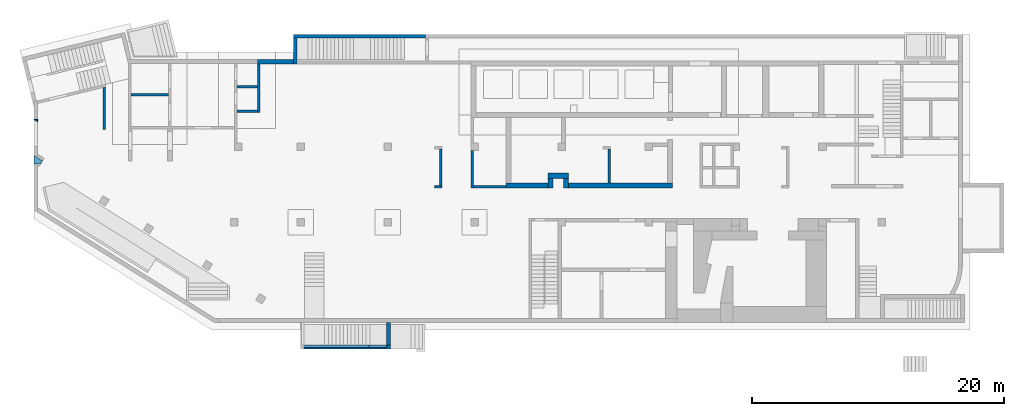
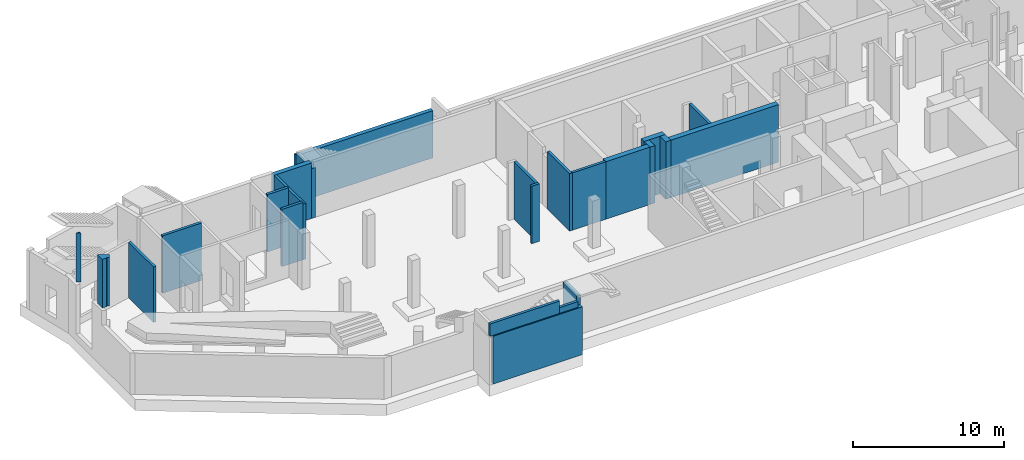
# One storey, part 2 of 9: 24 walls.
"""IFC4 building model written with IfcOpenShell, lengths in millimetres."""

from ifc_helpers import new_model, entity, si_unit, converted_unit, derived_unit, direction, frame, origin, place, context, subcontext, project, spatial, indexed_curve, outline, extrude, material, type_object, element, save


model = new_model("IFC4")

# Units and contexts
model_context = context("Model", 3, precision=0.01, world=origin(), true_north=direction((6.12303176911189e-17, 1.0)))
plan_context = context("Plan", 3, precision=0.01, world=origin(), true_north=direction((6.12303176911189e-17, 1.0)))
body_context = subcontext(model_context, "Body", "Model", "MODEL_VIEW")
ifc_project = project(units=[si_unit("LENGTHUNIT", "METRE", prefix="MILLI"), si_unit("AREAUNIT", "SQUARE_METRE"), si_unit("VOLUMEUNIT", "CUBIC_METRE"), converted_unit("PLANEANGLEUNIT", "DEGREE", entity("IfcRatioMeasure", 0.0174532925199433), si_unit("PLANEANGLEUNIT", "RADIAN"), dimensions=[0, 0, 0, 0, 0, 0, 0]), si_unit("MASSUNIT", "GRAM", prefix="KILO"), derived_unit("MASSDENSITYUNIT", [(si_unit("MASSUNIT", "GRAM", prefix="KILO"), 1), (si_unit("LENGTHUNIT", "METRE"), -3)]), derived_unit("MOMENTOFINERTIAUNIT", [(si_unit("LENGTHUNIT", "METRE"), 4)]), si_unit("TIMEUNIT", "SECOND"), si_unit("FREQUENCYUNIT", "HERTZ"), si_unit("THERMODYNAMICTEMPERATUREUNIT", "DEGREE_CELSIUS"), derived_unit("THERMALTRANSMITTANCEUNIT", [(si_unit("MASSUNIT", "GRAM", prefix="KILO"), 1), (si_unit("THERMODYNAMICTEMPERATUREUNIT", "KELVIN"), -1), (si_unit("TIMEUNIT", "SECOND"), -3)]), derived_unit("VOLUMETRICFLOWRATEUNIT", [(si_unit("LENGTHUNIT", "METRE"), 3), (si_unit("TIMEUNIT", "SECOND"), -1)]), derived_unit("MASSFLOWRATEUNIT", [(si_unit("MASSUNIT", "GRAM", prefix="KILO"), 1), (si_unit("TIMEUNIT", "SECOND"), -1)]), derived_unit("ROTATIONALFREQUENCYUNIT", [(si_unit("TIMEUNIT", "SECOND"), -1)]), si_unit("ELECTRICCURRENTUNIT", "AMPERE"), si_unit("ELECTRICVOLTAGEUNIT", "VOLT"), si_unit("POWERUNIT", "WATT"), si_unit("FORCEUNIT", "NEWTON", prefix="KILO"), si_unit("ILLUMINANCEUNIT", "LUX"), si_unit("LUMINOUSFLUXUNIT", "LUMEN"), si_unit("LUMINOUSINTENSITYUNIT", "CANDELA"), derived_unit("USERDEFINED", [(si_unit("MASSUNIT", "GRAM", prefix="KILO"), -1), (si_unit("LENGTHUNIT", "METRE"), -2), (si_unit("TIMEUNIT", "SECOND"), 3), (si_unit("LUMINOUSFLUXUNIT", "LUMEN"), 1)]), derived_unit("LINEARVELOCITYUNIT", [(si_unit("LENGTHUNIT", "METRE"), 1), (si_unit("TIMEUNIT", "SECOND"), -1)]), si_unit("PRESSUREUNIT", "PASCAL"), derived_unit("USERDEFINED", [(si_unit("LENGTHUNIT", "METRE"), -2), (si_unit("MASSUNIT", "GRAM", prefix="KILO"), 1), (si_unit("TIMEUNIT", "SECOND"), -2)]), derived_unit("LINEARFORCEUNIT", [(si_unit("MASSUNIT", "GRAM", prefix="KILO"), 1), (si_unit("LENGTHUNIT", "METRE"), 1), (si_unit("TIMEUNIT", "SECOND"), -2), (si_unit("LENGTHUNIT", "METRE"), -1)]), derived_unit("PLANARFORCEUNIT", [(si_unit("MASSUNIT", "GRAM", prefix="KILO"), 1), (si_unit("LENGTHUNIT", "METRE"), 1), (si_unit("TIMEUNIT", "SECOND"), -2), (si_unit("LENGTHUNIT", "METRE"), -2)])], contexts=[model_context, plan_context])

# Site, building, storey
site_placement = place(None, origin())
site = spatial("IfcSite", under=ifc_project, at=site_placement, CompositionType="ELEMENT")
building_placement = place(site_placement, origin())
building = spatial("IfcBuilding", under=site, at=building_placement, CompositionType="ELEMENT")
storey_placement = place(building_placement, frame((0.0, 0.0, -4900.0)))
storey = spatial("IfcBuildingStorey", under=building, at=storey_placement, CompositionType="ELEMENT", Elevation=-4900.0)

# Walls
ifc_material = material()
wall_type_1 = type_object("IfcWallType", PredefinedType="STANDARD")
wall_1_placement = place(storey_placement, frame((34770.0002685546, 13399.9992263563, 0.0), z_axis=(0.0, 0.0, 1.0), x_axis=(0.0, -1.0, 0.0)))
element("IfcWall", 1, at=wall_1_placement, inside=storey, type_object=wall_type_1, material=ifc_material, PredefinedType="NOTDEFINED", context=body_context, shape_type="SweptSolid", body=[
    extrude(outline(indexed_curve([(2975.00000000009, 99.9999999999989), (0.0, 99.9999999999989), (0.0, -99.9999999999989), (2975.00000000009, -99.9999999999989), (2975.00000000009, 99.9999999999989)], self_intersect=False)), origin(), (0.0, 0.0, 1.0), 4650.0),
])
wall_2_placement = place(storey_placement, frame((37465.0002685547, 10524.9992263562, 0.0), z_axis=(0.0, 0.0, 1.0), x_axis=(-1.0, 0.0, 0.0)))
element("IfcWall", 2, at=wall_2_placement, inside=storey, type_object=wall_type_1, material=ifc_material, PredefinedType="NOTDEFINED", context=body_context, shape_type="SweptSolid", body=[
    extrude(outline(indexed_curve([(2595.00000000001, 99.9999999999988), (-2.45985829439147e-13, 99.9999999999989), (2.45985829439147e-13, -99.9999999999989), (2595.00000000001, -99.999999999999), (2595.00000000001, 99.9999999999988)], self_intersect=False)), origin(), (0.0, 0.0, 1.0), 4650.0),
])
wall_3_placement = place(storey_placement, frame((45670.0002685547, 10824.9992263562, 0.0), z_axis=(0.0, 0.0, 1.0), x_axis=(0.0, 1.0, 0.0)))
element("IfcWall", 3, at=wall_3_placement, inside=storey, type_object=wall_type_1, material=ifc_material, PredefinedType="NOTDEFINED", context=body_context, shape_type="SweptSolid", body=[
    extrude(outline(indexed_curve([(2674.99999999998, 100.000000000003), (-3.01319549022173e-13, 100.000000000003), (3.01319549022173e-13, -100.000000000003), (2674.99999999998, -100.000000000004), (2674.99999999998, 100.000000000003)], self_intersect=False)), origin(), (0.0, 0.0, 1.0), 4650.0),
])
wall_4_placement = place(storey_placement, frame((32270.0002685546, 10624.9992263562, 0.0), z_axis=(0.0, 0.0, 1.0), x_axis=(0.0, 1.0, 0.0)))
element("IfcWall", 4, at=wall_4_placement, inside=storey, type_object=wall_type_1, material=ifc_material, PredefinedType="NOTDEFINED", context=body_context, shape_type="SweptSolid", body=[
    extrude(outline(indexed_curve([(2875.0, 100.000000000001), (-2.09532179305615e-13, 99.9999999999989), (2.09532179305615e-13, -99.9999999999989), (2875.0, -99.9999999999972), (2875.0, 100.000000000001)], self_intersect=False)), origin(), (0.0, 0.0, 1.0), 4650.0),
])
wall_5_placement = place(storey_placement, frame((32370.0002685546, 10524.9992263562, 0.0), z_axis=(0.0, 0.0, 1.0), x_axis=(-1.0, 0.0, 0.0)))
element("IfcWall", 5, at=wall_5_placement, inside=storey, type_object=wall_type_1, material=ifc_material, PredefinedType="NOTDEFINED", context=body_context, shape_type="SweptSolid", body=[
    extrude(outline(indexed_curve([(600.000000000001, 99.9999999999984), (-9.89300764987533e-13, 99.9999999999989), (9.89300764987533e-13, -99.9999999999989), (600.000000000003, -99.9999999999995), (600.000000000001, 99.9999999999984)], self_intersect=False)), origin(), (0.0, 0.0, 1.0), 4650.0),
])
wall_6_placement = place(storey_placement, frame((17825.0002685547, 20249.9992263562, 0.0), z_axis=(0.0, 0.0, 1.0), x_axis=(0.0, -1.0, 0.0)))
element("IfcWall", 6, at=wall_6_placement, inside=storey, type_object=wall_type_1, material=ifc_material, PredefinedType="NOTDEFINED", context=body_context, shape_type="SweptSolid", body=[
    extrude(outline(indexed_curve([(3850.00000000022, 99.9999999999992), (-1.75600075021359e-13, 99.9999999999989), (1.75600075021359e-13, -99.9999999999989), (3850.00000000022, -99.9999999999987), (3850.00000000022, 99.9999999999992)], self_intersect=False)), origin(), (0.0, 0.0, 1.0), 4500.0),
])
wall_7_placement = place(storey_placement, frame((17725.0002685547, 16499.9992263559, 0.0), z_axis=(0.0, 0.0, 1.0), x_axis=(-1.0, 0.0, 0.0)))
element("IfcWall", 7, at=wall_7_placement, inside=storey, type_object=wall_type_1, material=ifc_material, PredefinedType="NOTDEFINED", context=body_context, shape_type="SweptSolid", body=[
    extrude(outline(indexed_curve([(1624.99999999998, 99.9999999999989), (-2.66551908750373e-13, 99.9999999999989), (2.66551908750373e-13, -99.9999999999989), (1624.99999999998, -99.9999999999989), (1624.99999999998, 99.9999999999989)], self_intersect=False)), origin(), (0.0, 0.0, 1.0), 4650.0),
])
wall_8_placement = place(storey_placement, frame((10700.0002685547, 17799.9992263564, 0.0), z_axis=(0.0, 0.0, 1.0), x_axis=(-1.0, 0.0, 0.0)))
element("IfcWall", 8, at=wall_8_placement, inside=storey, type_object=wall_type_1, material=ifc_material, PredefinedType="NOTDEFINED", context=body_context, shape_type="SweptSolid", body=[
    extrude(outline(indexed_curve([(3000.0, 99.9999999999983), (-3.4002868983536e-13, 99.9999999999989), (3.4002868983536e-13, -99.9999999999989), (3000.0, -99.9999999999995), (3000.0, 99.9999999999983)], self_intersect=False)), origin(), (0.0, 0.0, 1.0), 4650.0),
])
wall_9_placement = place(storey_placement, frame((17725.0002685547, 18449.9992263561, 0.0), z_axis=(0.0, 0.0, 1.0), x_axis=(-1.0, 0.0, 0.0)))
element("IfcWall", 9, at=wall_9_placement, inside=storey, type_object=wall_type_1, material=ifc_material, PredefinedType="NOTDEFINED", context=body_context, shape_type="SweptSolid", body=[
    extrude(outline(indexed_curve([(1624.99999999999, 99.9999999999986), (-3.76649436277701e-13, 99.9999999999989), (3.76649436277701e-13, -99.9999999999989), (1624.99999999999, -99.9999999999993), (1624.99999999999, 99.9999999999986)], self_intersect=False)), origin(), (0.0, 0.0, 1.0), 4650.0),
])
wall_10_placement = place(storey_placement, frame((5600.00026855468, 15073.1293843001, 0.0), z_axis=(0.0, 0.0, 1.0), x_axis=(0.0, 1.0, 0.0)))
element("IfcWall", 10, at=wall_10_placement, inside=storey, type_object=wall_type_1, material=ifc_material, PredefinedType="NOTDEFINED", context=body_context, shape_type="SweptSolid", body=[
    extrude(outline(indexed_curve([(3362.07130066753, -100.0), (3313.31918470919, 99.9999999999997), (-1.53224901010752e-13, 100.0), (1.53224901010752e-13, -100.0), (3362.07130066753, -100.0)], self_intersect=False)), origin(), (0.0, 0.0, 1.0), 4500.0),
])
wall_11_placement = place(storey_placement, frame((21240.0002685546, -2150.0007736437, 3870.0)))
element("IfcWall", 11, at=wall_11_placement, inside=storey, type_object=wall_type_1, material=ifc_material, PredefinedType="NOTDEFINED", context=body_context, shape_type="SweptSolid", body=[
    extrude(outline(indexed_curve([(5350.0, 100.0), (-3.24069724826527e-13, 100.0), (3.24069724826527e-13, -100.0), (5350.0, -100.0), (5350.0, 100.0)], self_intersect=False)), origin(), (0.0, 0.0, 1.0), 999.999999999997),
])
wall_12_placement = place(storey_placement, frame((26590.0002685546, -2150.00077364372, 3870.0)))
element("IfcWall", 12, at=wall_12_placement, inside=storey, type_object=wall_type_1, material=ifc_material, PredefinedType="NOTDEFINED", context=body_context, shape_type="SweptSolid", body=[
    extrude(outline(indexed_curve([(1400.0, 99.9999999999999), (-3.24069724826527e-13, 100.0), (3.24069724826527e-13, -100.0), (1400.0, -100.0), (1400.0, 99.9999999999999)], self_intersect=False)), origin(), (0.0, 0.0, 1.0), 455.0),
])
wall_type_2 = type_object("IfcWallType", PredefinedType="STANDARD")
wall_13_placement = place(storey_placement, frame((21440.0002685546, -2200.00077364371, 0.0)))
element("IfcWall", 13, at=wall_13_placement, inside=storey, type_object=wall_type_2, material=ifc_material, PredefinedType="NOTDEFINED", context=body_context, shape_type="SweptSolid", body=[
    extrude(outline(indexed_curve([(6849.99999999999, 150.0), (-4.88206460399072e-13, 150.0), (4.88206460399072e-13, -150.0), (6849.99999999999, -150.0), (6849.99999999999, 150.0)], self_intersect=False)), origin(), (0.0, 0.0, 1.0), 3870.0),
])
wall_14_placement = place(storey_placement, frame((28140.0002685546, -2250.00077364373, 0.0), z_axis=(0.0, 0.0, 1.0), x_axis=(0.0, 1.0, 0.0)))
element("IfcWall", 14, at=wall_14_placement, inside=storey, type_object=wall_type_2, material=ifc_material, PredefinedType="NOTDEFINED", context=body_context, shape_type="SweptSolid", body=[
    extrude(outline(indexed_curve([(1999.99999999999, -149.999999999999), (1999.99999999999, 150.000000000002), (200.000000000001, 150.000000000001), (200.0, -150.0), (1399.99999999983, -150.000000000001), (1999.99999999999, -149.999999999999)], self_intersect=False)), origin(), (0.0, 0.0, 1.0), 4700.0),
])
wall_15_placement = place(storey_placement, frame((20740.0002685547, 20249.9992263562, 0.0), z_axis=(0.0, 0.0, 1.0), x_axis=(0.0, 1.0, 0.0)))
element("IfcWall", 15, at=wall_15_placement, inside=storey, type_object=wall_type_2, material=ifc_material, PredefinedType="NOTDEFINED", context=body_context, shape_type="SweptSolid", body=[
    extrude(outline(indexed_curve([(2049.99999999993, 150.000000000001), (0.0, 150.000000000001), (0.0, -150.000000000001), (2049.99999999993, -150.000000000001), (2049.99999999993, 150.000000000001)], self_intersect=False)), origin(), (0.0, 0.0, 1.0), 4035.0),
])
wall_16_placement = place(storey_placement, frame((31060.0002685547, 22449.9992263561, 0.0), z_axis=(0.0, 0.0, 1.0), x_axis=(-1.0, 0.0, 0.0)))
element("IfcWall", 16, at=wall_16_placement, inside=storey, type_object=wall_type_2, material=ifc_material, PredefinedType="NOTDEFINED", context=body_context, shape_type="SweptSolid", body=[
    extrude(outline(indexed_curve([(10470.0, 149.999999999999), (-4.06075069700321e-13, 150.000000000001), (4.06075069700321e-13, -150.000000000001), (10470.0, -150.000000000003), (10470.0, 149.999999999999)], self_intersect=False)), origin(), (0.0, 0.0, 1.0), 3825.0),
])
wall_type_3 = type_object("IfcWallType", PredefinedType="STANDARD")
wall_17_placement = place(storey_placement, frame((37465.0002685547, 10624.9992263562, 0.0)))
element("IfcWall", 17, at=wall_17_placement, inside=storey, type_object=wall_type_3, material=ifc_material, PredefinedType="NOTDEFINED", context=body_context, shape_type="SweptSolid", body=[
    extrude(outline(indexed_curve([(3340.00000000001, 200.0), (-6.53955811791895e-13, 200.0), (6.53955811791895e-13, -200.0), (3340.00000000001, -200.0), (3340.00000000001, 200.0)], self_intersect=False)), origin(), (0.0, 0.0, 1.0), 4650.0),
])
wall_18_placement = place(storey_placement, frame((40805.0002685547, 11384.9992263562, 0.0)))
element("IfcWall", 18, at=wall_18_placement, inside=storey, type_object=wall_type_3, material=ifc_material, PredefinedType="NOTDEFINED", context=body_context, shape_type="SweptSolid", body=[
    extrude(outline(indexed_curve([(1629.99999999998, 200.000000000001), (-6.30612781303807e-13, 200.0), (6.30612781303807e-13, -200.0), (1629.99999999999, -199.999999999999), (1629.99999999998, 200.000000000001)], self_intersect=False)), origin(), (0.0, 0.0, 1.0), 4650.0),
])
for number, where, z_axis, x_axis in (
    (19, (41005.0002685547, 11184.9992263562, 0.0), (0.0, 0.0, 1.0), (0.0, -1.0, 0.0)),
    (20, (42235.0002685547, 11184.9992263562, 0.0), (0.0, 0.0, 1.0), (0.0, -1.0, 0.0)),
):
    element("IfcWall", number, at=place(storey_placement, frame(where, z_axis=z_axis, x_axis=x_axis)), inside=storey, type_object=wall_type_3, material=ifc_material, PredefinedType="NOTDEFINED", context=body_context, shape_type="SweptSolid", body=[
        extrude(outline(indexed_curve([(759.999999999996, 199.999999999998), (0.0, 199.999999999998), (0.0, -199.999999999998), (759.999999999996, -199.999999999998), (759.999999999996, 199.999999999998)], self_intersect=False)), origin(), (0.0, 0.0, 1.0), 4650.0),
    ])
wall_19_placement = place(storey_placement, frame((42435.0002685547, 10624.9992263562, 0.0)))
element("IfcWall", 21, at=wall_19_placement, inside=storey, type_object=wall_type_3, material=ifc_material, PredefinedType="NOTDEFINED", context=body_context, shape_type="SweptSolid", body=[
    extrude(outline(indexed_curve([(8235.0, 200.000000000001), (-6.53955811791895e-13, 200.0), (6.53955811791895e-13, -200.0), (8235.0, -199.999999999999), (8235.0, 200.000000000001)], self_intersect=False)), origin(), (0.0, 0.0, 1.0), 4650.0),
])
wall_type_4 = type_object("IfcWallType", PredefinedType="STANDARD")
wall_20_placement = place(storey_placement, frame((20740.0002685547, 20424.9992263562, 0.0), z_axis=(0.0, 0.0, 1.0), x_axis=(-1.0, 0.0, 0.0)))
element("IfcWall", 22, at=wall_20_placement, inside=storey, type_object=wall_type_4, material=ifc_material, PredefinedType="NOTDEFINED", context=body_context, shape_type="SweptSolid", body=[
    extrude(outline(indexed_curve([(3015.00000000001, -174.999999999998), (3015.00000000001, 124.999999999834), (3015.00000000001, 175.0), (2815.00000000001, 175.0), (150.0, 175.0), (150.000000000001, -174.999999999999), (3015.00000000001, -174.999999999998)], self_intersect=False)), origin(), (0.0, 0.0, 1.0), 4500.0),
])
wall_type_5 = type_object("IfcWallType", PredefinedType="NOTDEFINED", material=ifc_material)
wall_21_placement = place(storey_placement, frame((0.211875130563434, 12305.1155292181, 4750.0)))
element("IfcWall", 23, at=wall_21_placement, inside=storey, type_object=wall_type_5, material=ifc_material, PredefinedType="NOTDEFINED", context=body_context, shape_type="SweptSolid", body=[
    extrude(outline(indexed_curve([(-131.231739163563, 98.4108115764556), (-393.432576023938, -46.9294855937384), (-74.3712552153423, -622.531345192431), (322.209288883721, 92.9040970677975), (234.747743375137, 141.385826175261), (59.824652357967, 238.349284390191), (-17.7461142139768, 98.4108115764556), (-131.231739163563, 98.4108115764556)], self_intersect=False)), frame((366.855750510212, 179.4614143192, 0.0), z_axis=(0.0, 0.0, -1.0), x_axis=(0.8746197071394, 0.48480962024633, 0.0)), (0.0, 0.0, -1.0), 3950.0),
])
wall_type_6 = type_object("IfcWallType", PredefinedType="NOTDEFINED", material=ifc_material)
wall_22_placement = place(storey_placement, frame((0.000268554665045251, 15664.9992263565, 4750.0)))
element("IfcWall", 24, at=wall_22_placement, inside=storey, type_object=wall_type_6, material=ifc_material, PredefinedType="NOTDEFINED", context=body_context, shape_type="SweptSolid", body=[
    extrude(outline(indexed_curve([(-124.971431388, -100.0), (62.4857156940014, -100.0), (62.4857156940009, 200.0), (-124.971431388, -100.0)], self_intersect=False)), frame((200.0, 124.971431388, 0.0), z_axis=(0.0, 0.0, 1.0), x_axis=(0.0, 1.0, 0.0)), (0.0, 0.0, 1.0), 3950.0),
])

save(model, "model.ifc")
